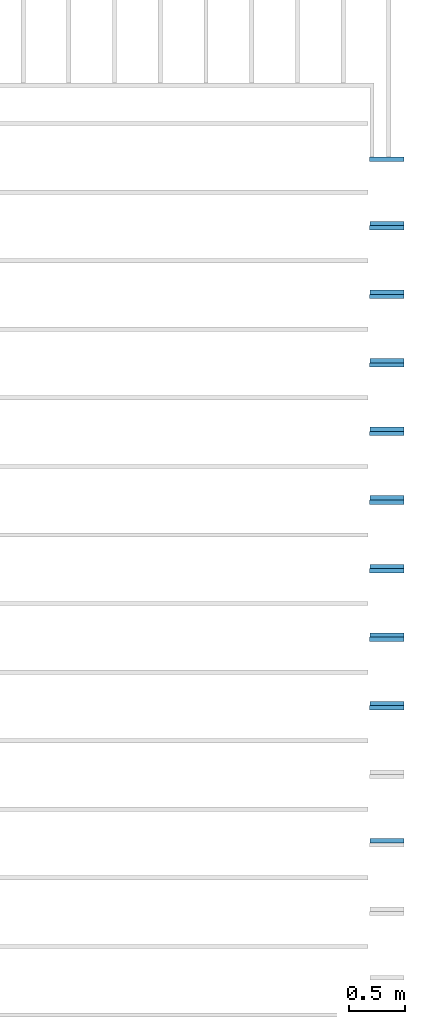
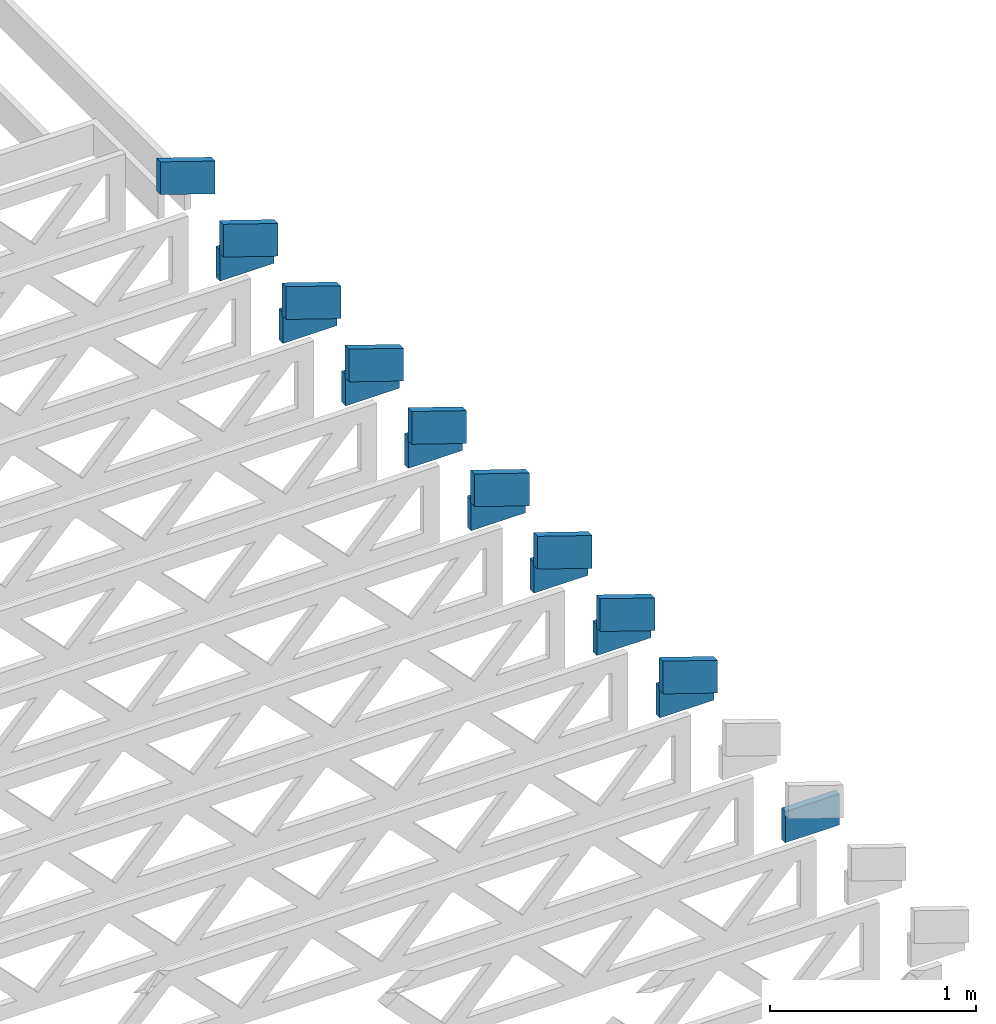
# One storey, part 16 of 17: 18 beams, 2 elements without a shape of their own.
"""IFC4 building model written with IfcOpenShell, lengths in feet."""

from ifc_helpers import new_model, entity, si_unit, converted_unit, derived_unit, direction, frame, frame_2d, origin, origin_2d_with_axis, place, context, subcontext, project, spatial, rectangle, extrude, clip, halfspace, source, transform, mapped, material, material_profile, profile_set, profile_usage, type_object, type_shapes, element, aggregate, save


model = new_model("IFC4")

# Units and contexts
model_context = context("Model", 3, precision=0.0001, world=origin(), true_north=direction((6.12303176911189e-17, 1.0)))
body_context = subcontext(model_context, "Body", "Model", "MODEL_VIEW")
ifc_project = project(units=[converted_unit("LENGTHUNIT", "FOOT", entity("IfcRatioMeasure", 0.3048), si_unit("LENGTHUNIT", "METRE"), dimensions=[1, 0, 0, 0, 0, 0, 0]), converted_unit("AREAUNIT", "SQUARE FOOT", entity("IfcRatioMeasure", 0.09290304), si_unit("AREAUNIT", "SQUARE_METRE"), dimensions=[2, 0, 0, 0, 0, 0, 0]), converted_unit("VOLUMEUNIT", "CUBIC FOOT", entity("IfcRatioMeasure", 0.028316846592), si_unit("VOLUMEUNIT", "CUBIC_METRE"), dimensions=[3, 0, 0, 0, 0, 0, 0]), converted_unit("PLANEANGLEUNIT", "DEGREE", entity("IfcRatioMeasure", 0.0174532925199433), si_unit("PLANEANGLEUNIT", "RADIAN"), dimensions=[0, 0, 0, 0, 0, 0, 0]), si_unit("MASSUNIT", "GRAM", prefix="KILO"), derived_unit("MASSDENSITYUNIT", [(si_unit("MASSUNIT", "GRAM", prefix="KILO"), 1), (si_unit("LENGTHUNIT", "METRE"), -3)]), derived_unit("MOMENTOFINERTIAUNIT", [(si_unit("LENGTHUNIT", "METRE"), 4)]), si_unit("TIMEUNIT", "SECOND"), si_unit("FREQUENCYUNIT", "HERTZ"), si_unit("THERMODYNAMICTEMPERATUREUNIT", "DEGREE_CELSIUS"), derived_unit("THERMALTRANSMITTANCEUNIT", [(si_unit("MASSUNIT", "GRAM", prefix="KILO"), 1), (si_unit("THERMODYNAMICTEMPERATUREUNIT", "KELVIN"), -1), (si_unit("TIMEUNIT", "SECOND"), -3)]), derived_unit("VOLUMETRICFLOWRATEUNIT", [(si_unit("LENGTHUNIT", "METRE"), 3), (si_unit("TIMEUNIT", "SECOND"), -1)]), si_unit("ELECTRICCURRENTUNIT", "AMPERE"), si_unit("ELECTRICVOLTAGEUNIT", "VOLT"), si_unit("POWERUNIT", "WATT"), si_unit("FORCEUNIT", "NEWTON"), si_unit("ILLUMINANCEUNIT", "LUX"), si_unit("LUMINOUSFLUXUNIT", "LUMEN"), si_unit("LUMINOUSINTENSITYUNIT", "CANDELA"), derived_unit("USERDEFINED", [(si_unit("MASSUNIT", "GRAM", prefix="KILO"), -1), (si_unit("LENGTHUNIT", "METRE"), -2), (si_unit("TIMEUNIT", "SECOND"), 3), (si_unit("LUMINOUSFLUXUNIT", "LUMEN"), 1)]), derived_unit("LINEARVELOCITYUNIT", [(si_unit("LENGTHUNIT", "METRE"), 1), (si_unit("TIMEUNIT", "SECOND"), -1)]), si_unit("PRESSUREUNIT", "PASCAL"), derived_unit("USERDEFINED", [(si_unit("LENGTHUNIT", "METRE"), -2), (si_unit("MASSUNIT", "GRAM", prefix="KILO"), 1), (si_unit("TIMEUNIT", "SECOND"), -2)]), derived_unit("LINEARFORCEUNIT", [(si_unit("MASSUNIT", "GRAM", prefix="KILO"), 1), (si_unit("LENGTHUNIT", "METRE"), 1), (si_unit("TIMEUNIT", "SECOND"), -2), (si_unit("LENGTHUNIT", "METRE"), -1)]), derived_unit("PLANARFORCEUNIT", [(si_unit("MASSUNIT", "GRAM", prefix="KILO"), 1), (si_unit("LENGTHUNIT", "METRE"), 1), (si_unit("TIMEUNIT", "SECOND"), -2), (si_unit("LENGTHUNIT", "METRE"), -2)])], contexts=[model_context])

# Site, building, storey
site_placement = place(None, origin())
site = spatial("IfcSite", under=ifc_project, at=site_placement, CompositionType="ELEMENT")
building_placement = place(site_placement, origin())
building = spatial("IfcBuilding", under=site, at=building_placement, CompositionType="ELEMENT")
storey_placement = place(building_placement, frame((0.0, 0.0, 30.4375000000082)))
storey = spatial("IfcBuildingStorey", under=building, at=storey_placement, Name="ROOF", CompositionType="ELEMENT", Elevation=30.4375000000082)

# Assembly, beams
assembly_1_placement = place(storey_placement, origin())
assembly_1 = element("IfcElementAssembly", 1, at=assembly_1_placement, inside=storey, Name="Structural Beam System:Structural Framing System", ObjectType="Structural Beam System:Structural Framing System", AssemblyPlace="NOTDEFINED", PredefinedType="BEAM_GRID")
ifc_material_1 = material(Name="TOP CHORD OF FIELD FRAMED OVERHANG", Category="Materials")
ifc_material_profile_1 = material_profile(ifc_material_1, rectangle(XDim=0.604166666666667, YDim=0.125, at=origin_2d_with_axis()), Name="2X8 TOP CHORD")
ifc_profile_set_1 = profile_set([ifc_material_profile_1], Name="2X8 TOP CHORD")
ifc_profile_usage_1 = profile_usage(ifc_profile_set_1, cardinal=8)
beam_type_1 = type_object("IfcBeamType", Name="Dimension Lumber - Ends:2X8 TOP CHORD", PredefinedType="BEAM", material=ifc_profile_set_1)
shared_shape_1 = source(origin(), body_context, "Body", "Clipping", [
    clip(clip(extrude(rectangle(XDim=0.604166666666671, YDim=0.125, at=frame_2d((-1.52655665885959e-15, 0.0), x_axis=(1.0, 0.0))), frame((-0.529560098375526, 0.0, 0.0), z_axis=(1.0, 0.0, 0.0), x_axis=(0.0, 0.0, -1.0)), (0.0, 0.0, 1.0), 1.26045110526351), halfspace(frame((0.529560098375489, -0.0625000000000025, -0.302083333333339), z_axis=(0.948710608132914, 0.0, -0.316145823973805), x_axis=(0.0, 1.0, 0.0)), False)), halfspace(frame((-0.328229189863038, -0.0625000000000025, 0.302083333333328), z_axis=(-0.948710608132914, 0.0, 0.316145823973805), x_axis=(0.0, 1.0, 0.0)), False)),
])
type_shapes(beam_type_1, [shared_shape_1])
beam_1_placement = place(assembly_1_placement, frame((-139.765291953278, 956.820268401833, 1.43770432947422), z_axis=(0.316227766016836, 0.0, 0.948683298050515), x_axis=(-0.948683298050516, 0.0, 0.316227766016833)))
beam_1 = element("IfcBeam", 2, at=beam_1_placement, type_object=beam_type_1, material=ifc_profile_usage_1, Name="Dimension Lumber - Ends:2X8 TOP CHORD", ObjectType="Dimension Lumber - Ends:2X8 TOP CHORD", PredefinedType="BEAM", context=body_context, shape_type="MappedRepresentation", body=[
    mapped(shared_shape_1, transform((0.0, 0.0, 0.0), scale=1.0)),
])
ifc_profile_usage_2 = profile_usage(ifc_profile_set_1, cardinal=8)
beam_2_placement = place(assembly_1_placement, frame((-139.765291953278, 954.820268401833, 1.43770432947422), z_axis=(0.316227766016839, 0.0, 0.948683298050514), x_axis=(-0.948683298050515, 0.0, 0.316227766016836)))
beam_2 = element("IfcBeam", 3, at=beam_2_placement, type_object=beam_type_1, material=ifc_profile_usage_2, Name="Dimension Lumber - Ends:2X8 TOP CHORD", ObjectType="Dimension Lumber - Ends:2X8 TOP CHORD", PredefinedType="BEAM", context=body_context, shape_type="MappedRepresentation", body=[
    mapped(shared_shape_1, transform((0.0, 0.0, 0.0), scale=1.0)),
])
ifc_profile_usage_3 = profile_usage(ifc_profile_set_1, cardinal=8)
beam_3_placement = place(assembly_1_placement, frame((-139.765291953277, 952.820268401833, 1.43770432947489), z_axis=(0.31622776601683, 0.0, 0.948683298050517), x_axis=(-0.948683298050516, 0.0, 0.316227766016833)))
beam_3 = element("IfcBeam", 4, at=beam_3_placement, type_object=beam_type_1, material=ifc_profile_usage_3, Name="Dimension Lumber - Ends:2X8 TOP CHORD", ObjectType="Dimension Lumber - Ends:2X8 TOP CHORD", PredefinedType="BEAM", context=body_context, shape_type="MappedRepresentation", body=[
    mapped(shared_shape_1, transform((0.0, 0.0, 0.0), scale=1.0)),
])
ifc_profile_usage_4 = profile_usage(ifc_profile_set_1, cardinal=8)
beam_4_placement = place(assembly_1_placement, frame((-139.765291953277, 950.820268401833, 1.43770432947488), z_axis=(0.31622776601683, 0.0, 0.948683298050517), x_axis=(-0.948683298050516, 0.0, 0.316227766016833)))
beam_4 = element("IfcBeam", 5, at=beam_4_placement, type_object=beam_type_1, material=ifc_profile_usage_4, Name="Dimension Lumber - Ends:2X8 TOP CHORD", ObjectType="Dimension Lumber - Ends:2X8 TOP CHORD", PredefinedType="BEAM", context=body_context, shape_type="MappedRepresentation", body=[
    mapped(shared_shape_1, transform((0.0, 0.0, 0.0), scale=1.0)),
])
ifc_profile_usage_5 = profile_usage(ifc_profile_set_1, cardinal=8)
beam_5_placement = place(assembly_1_placement, frame((-139.765291953278, 948.820268401833, 1.43770432947416), z_axis=(0.316227766016839, 0.0, 0.948683298050514), x_axis=(-0.948683298050515, 0.0, 0.316227766016836)))
beam_5 = element("IfcBeam", 6, at=beam_5_placement, type_object=beam_type_1, material=ifc_profile_usage_5, Name="Dimension Lumber - Ends:2X8 TOP CHORD", ObjectType="Dimension Lumber - Ends:2X8 TOP CHORD", PredefinedType="BEAM", context=body_context, shape_type="MappedRepresentation", body=[
    mapped(shared_shape_1, transform((0.0, 0.0, 0.0), scale=1.0)),
])
ifc_profile_usage_6 = profile_usage(ifc_profile_set_1, cardinal=8)
beam_6_placement = place(assembly_1_placement, frame((-139.765291953277, 946.820268401833, 1.43770432947486), z_axis=(0.316227766016833, 0.0, 0.948683298050516), x_axis=(-0.948683298050515, 0.0, 0.316227766016836)))
beam_6 = element("IfcBeam", 7, at=beam_6_placement, type_object=beam_type_1, material=ifc_profile_usage_6, Name="Dimension Lumber - Ends:2X8 TOP CHORD", ObjectType="Dimension Lumber - Ends:2X8 TOP CHORD", PredefinedType="BEAM", context=body_context, shape_type="MappedRepresentation", body=[
    mapped(shared_shape_1, transform((0.0, 0.0, 0.0), scale=1.0)),
])
ifc_profile_usage_7 = profile_usage(ifc_profile_set_1, cardinal=8)
beam_7_placement = place(assembly_1_placement, frame((-139.765291953277, 944.820268401833, 1.43770432947485), z_axis=(0.316227766016833, 0.0, 0.948683298050516), x_axis=(-0.948683298050515, 0.0, 0.316227766016836)))
beam_7 = element("IfcBeam", 8, at=beam_7_placement, type_object=beam_type_1, material=ifc_profile_usage_7, Name="Dimension Lumber - Ends:2X8 TOP CHORD", ObjectType="Dimension Lumber - Ends:2X8 TOP CHORD", PredefinedType="BEAM", context=body_context, shape_type="MappedRepresentation", body=[
    mapped(shared_shape_1, transform((0.0, 0.0, 0.0), scale=1.0)),
])
ifc_profile_usage_8 = profile_usage(ifc_profile_set_1, cardinal=8)
beam_8_placement = place(assembly_1_placement, frame((-139.765291953277, 942.820268401833, 1.43770432947483), z_axis=(0.316227766016833, 0.0, 0.948683298050516), x_axis=(-0.948683298050515, 0.0, 0.316227766016836)))
beam_8 = element("IfcBeam", 9, at=beam_8_placement, type_object=beam_type_1, material=ifc_profile_usage_8, Name="Dimension Lumber - Ends:2X8 TOP CHORD", ObjectType="Dimension Lumber - Ends:2X8 TOP CHORD", PredefinedType="BEAM", context=body_context, shape_type="MappedRepresentation", body=[
    mapped(shared_shape_1, transform((0.0, 0.0, 0.0), scale=1.0)),
])
ifc_profile_usage_9 = profile_usage(ifc_profile_set_1, cardinal=8)
beam_9_placement = place(assembly_1_placement, frame((-139.765291953278, 940.820268401833, 1.43770432947409), z_axis=(0.316227766016839, 0.0, 0.948683298050514), x_axis=(-0.948683298050515, 0.0, 0.316227766016836)))
beam_9 = element("IfcBeam", 10, at=beam_9_placement, type_object=beam_type_1, material=ifc_profile_usage_9, Name="Dimension Lumber - Ends:2X8 TOP CHORD", ObjectType="Dimension Lumber - Ends:2X8 TOP CHORD", PredefinedType="BEAM", context=body_context, shape_type="MappedRepresentation", body=[
    mapped(shared_shape_1, transform((0.0, 0.0, 0.0), scale=1.0)),
])
aggregate(assembly_1, [beam_1, beam_2, beam_3, beam_4, beam_5, beam_6, beam_7, beam_8, beam_9])

assembly_2_placement = place(storey_placement, origin())
assembly_2 = element("IfcElementAssembly", 11, at=assembly_2_placement, inside=storey, Name="Structural Beam System:Structural Framing System", ObjectType="Structural Beam System:Structural Framing System", AssemblyPlace="NOTDEFINED", PredefinedType="BEAM_GRID")
ifc_material_2 = material(Name="BOTTOM CHORD OF FIELD FRAMED OVERHANG", Category="Materials")
ifc_material_profile_2 = material_profile(ifc_material_2, rectangle(XDim=0.604166666666667, YDim=0.125000000000011, at=origin_2d_with_axis()), Name="2X8 - BOTTOM CHORD")
ifc_profile_set_2 = profile_set([ifc_material_profile_2], Name="2X8 - BOTTOM CHORD")
ifc_profile_usage_10 = profile_usage(ifc_profile_set_2, cardinal=8)
beam_type_2 = type_object("IfcBeamType", Name="061100 - Wood Framing:2X8 - BOTTOM CHORD", PredefinedType="BEAM", material=ifc_profile_set_2)
shared_shape_2 = source(origin(), body_context, "Body", "SweptSolid", [
    extrude(rectangle(XDim=0.604166666666667, YDim=0.125000000000011, at=origin_2d_with_axis()), frame((-0.497179684451055, 0.0, 0.0), z_axis=(1.0, 0.0, 0.0), x_axis=(0.0, 0.0, -1.0)), (0.0, 0.0, 1.0), 0.99435936890211),
])
type_shapes(beam_type_2, [shared_shape_2])
beam_10_placement = place(assembly_2_placement, frame((-139.855564134411, 954.945268401832, 1.07291666665407)))
beam_10 = element("IfcBeam", 12, at=beam_10_placement, type_object=beam_type_2, material=ifc_profile_usage_10, Name="061100 - Wood Framing:2X8 - BOTTOM CHORD", ObjectType="061100 - Wood Framing:2X8 - BOTTOM CHORD", PredefinedType="BEAM", context=body_context, shape_type="MappedRepresentation", body=[
    mapped(shared_shape_2, transform((0.0, 0.0, 0.0), scale=1.0)),
])
ifc_profile_usage_11 = profile_usage(ifc_profile_set_2, cardinal=8)
beam_11_placement = place(assembly_2_placement, frame((-139.855564134411, 952.945268401832, 1.07291666665407)))
beam_11 = element("IfcBeam", 13, at=beam_11_placement, type_object=beam_type_2, material=ifc_profile_usage_11, Name="061100 - Wood Framing:2X8 - BOTTOM CHORD", ObjectType="061100 - Wood Framing:2X8 - BOTTOM CHORD", PredefinedType="BEAM", context=body_context, shape_type="MappedRepresentation", body=[
    mapped(shared_shape_2, transform((0.0, 0.0, 0.0), scale=1.0)),
])
ifc_profile_usage_12 = profile_usage(ifc_profile_set_2, cardinal=8)
beam_12_placement = place(assembly_2_placement, frame((-139.855564134411, 950.945268401832, 1.07291666665407)))
beam_12 = element("IfcBeam", 14, at=beam_12_placement, type_object=beam_type_2, material=ifc_profile_usage_12, Name="061100 - Wood Framing:2X8 - BOTTOM CHORD", ObjectType="061100 - Wood Framing:2X8 - BOTTOM CHORD", PredefinedType="BEAM", context=body_context, shape_type="MappedRepresentation", body=[
    mapped(shared_shape_2, transform((0.0, 0.0, 0.0), scale=1.0)),
])
ifc_profile_usage_13 = profile_usage(ifc_profile_set_2, cardinal=8)
beam_13_placement = place(assembly_2_placement, frame((-139.855564134411, 948.945268401832, 1.07291666665407)))
beam_13 = element("IfcBeam", 15, at=beam_13_placement, type_object=beam_type_2, material=ifc_profile_usage_13, Name="061100 - Wood Framing:2X8 - BOTTOM CHORD", ObjectType="061100 - Wood Framing:2X8 - BOTTOM CHORD", PredefinedType="BEAM", context=body_context, shape_type="MappedRepresentation", body=[
    mapped(shared_shape_2, transform((0.0, 0.0, 0.0), scale=1.0)),
])
ifc_profile_usage_14 = profile_usage(ifc_profile_set_2, cardinal=8)
beam_14_placement = place(assembly_2_placement, frame((-139.855564134411, 946.945268401832, 1.07291666665407)))
beam_14 = element("IfcBeam", 16, at=beam_14_placement, type_object=beam_type_2, material=ifc_profile_usage_14, Name="061100 - Wood Framing:2X8 - BOTTOM CHORD", ObjectType="061100 - Wood Framing:2X8 - BOTTOM CHORD", PredefinedType="BEAM", context=body_context, shape_type="MappedRepresentation", body=[
    mapped(shared_shape_2, transform((0.0, 0.0, 0.0), scale=1.0)),
])
ifc_profile_usage_15 = profile_usage(ifc_profile_set_2, cardinal=8)
beam_15_placement = place(assembly_2_placement, frame((-139.855564134411, 944.945268401832, 1.07291666665407)))
beam_15 = element("IfcBeam", 17, at=beam_15_placement, type_object=beam_type_2, material=ifc_profile_usage_15, Name="061100 - Wood Framing:2X8 - BOTTOM CHORD", ObjectType="061100 - Wood Framing:2X8 - BOTTOM CHORD", PredefinedType="BEAM", context=body_context, shape_type="MappedRepresentation", body=[
    mapped(shared_shape_2, transform((0.0, 0.0, 0.0), scale=1.0)),
])
ifc_profile_usage_16 = profile_usage(ifc_profile_set_2, cardinal=8)
beam_16_placement = place(assembly_2_placement, frame((-139.855564134411, 942.945268401832, 1.07291666665407)))
beam_16 = element("IfcBeam", 18, at=beam_16_placement, type_object=beam_type_2, material=ifc_profile_usage_16, Name="061100 - Wood Framing:2X8 - BOTTOM CHORD", ObjectType="061100 - Wood Framing:2X8 - BOTTOM CHORD", PredefinedType="BEAM", context=body_context, shape_type="MappedRepresentation", body=[
    mapped(shared_shape_2, transform((0.0, 0.0, 0.0), scale=1.0)),
])
ifc_profile_usage_17 = profile_usage(ifc_profile_set_2, cardinal=8)
beam_17_placement = place(assembly_2_placement, frame((-139.855564134411, 940.945268401832, 1.07291666665407)))
beam_17 = element("IfcBeam", 19, at=beam_17_placement, type_object=beam_type_2, material=ifc_profile_usage_17, Name="061100 - Wood Framing:2X8 - BOTTOM CHORD", ObjectType="061100 - Wood Framing:2X8 - BOTTOM CHORD", PredefinedType="BEAM", context=body_context, shape_type="MappedRepresentation", body=[
    mapped(shared_shape_2, transform((0.0, 0.0, 0.0), scale=1.0)),
])
ifc_profile_usage_18 = profile_usage(ifc_profile_set_2, cardinal=8)
beam_18_placement = place(assembly_2_placement, frame((-139.855564134411, 936.945268401832, 1.07291666665407)))
beam_18 = element("IfcBeam", 20, at=beam_18_placement, type_object=beam_type_2, material=ifc_profile_usage_18, Name="061100 - Wood Framing:2X8 - BOTTOM CHORD", ObjectType="061100 - Wood Framing:2X8 - BOTTOM CHORD", PredefinedType="BEAM", context=body_context, shape_type="MappedRepresentation", body=[
    mapped(shared_shape_2, transform((0.0, 0.0, 0.0), scale=1.0)),
])
aggregate(assembly_2, [beam_10, beam_11, beam_12, beam_13, beam_14, beam_15, beam_16, beam_17, beam_18])

save(model, "model.ifc")
